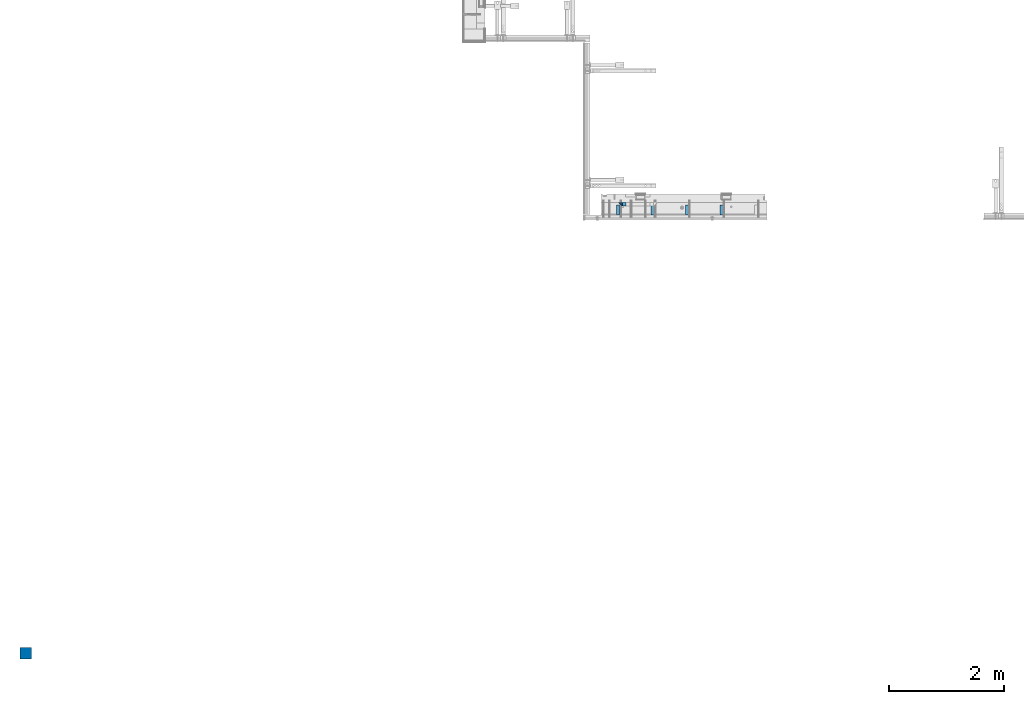
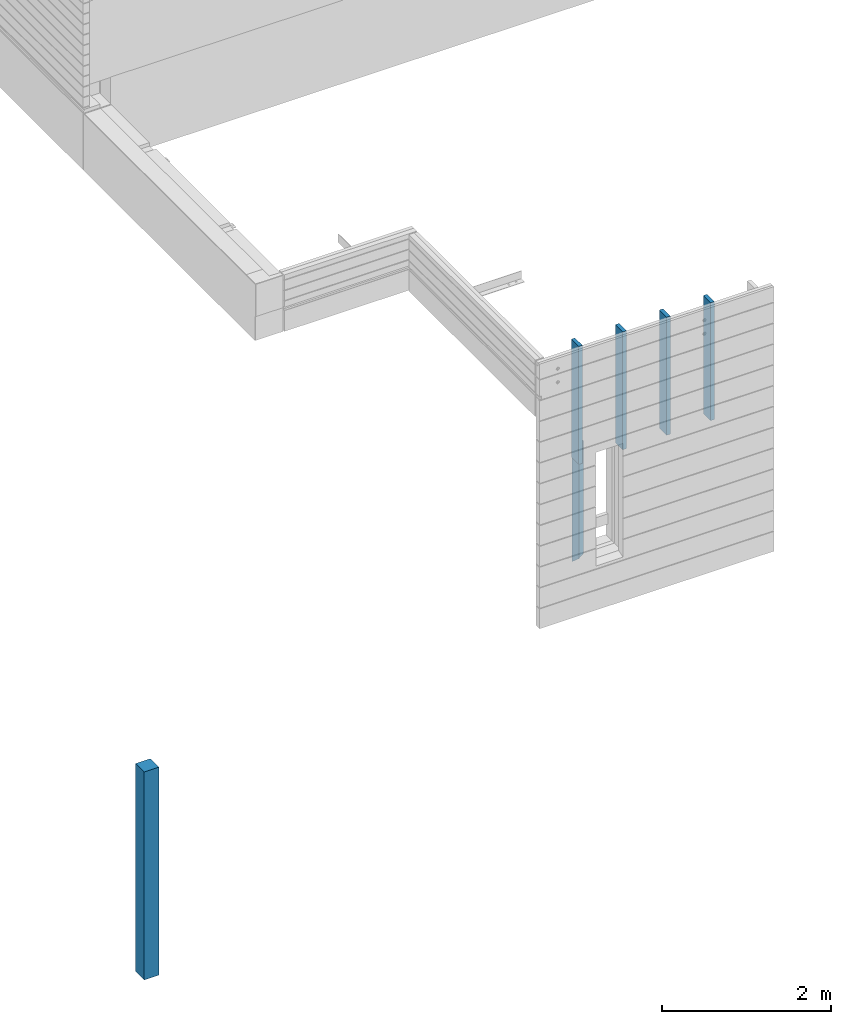
# One storey, part 1 of 153: 7 columns, 2 elements without a shape of their own.
"""IFC2X3 building model written with IfcOpenShell, lengths in millimetres."""

from ifc_helpers import new_model, si_unit, frame, origin_with_axes, place, context, subcontext, project, spatial, faceted_brep, material, type_object, element, aggregate, save


model = new_model("IFC2X3")

# Units and contexts
model_context = context("Model", 3, precision=1e-05, world=origin_with_axes())
body_context = subcontext(model_context, "Body", "Model", "MODEL_VIEW")
ifc_project = project(units=[si_unit("LENGTHUNIT", "METRE", prefix="MILLI"), si_unit("AREAUNIT", "SQUARE_METRE"), si_unit("VOLUMEUNIT", "CUBIC_METRE"), si_unit("MASSUNIT", "GRAM", prefix="KILO"), si_unit("TIMEUNIT", "SECOND"), si_unit("PLANEANGLEUNIT", "RADIAN"), si_unit("SOLIDANGLEUNIT", "STERADIAN"), si_unit("THERMODYNAMICTEMPERATUREUNIT", "DEGREE_CELSIUS"), si_unit("LUMINOUSINTENSITYUNIT", "LUMEN")], contexts=[model_context])

# Site, building, storey
site_placement = place(None, origin_with_axes())
site = spatial("IfcSite", under=ifc_project, at=site_placement, CompositionType="ELEMENT")
building_placement = place(site_placement, origin_with_axes())
building = spatial("IfcBuilding", under=site, at=building_placement, CompositionType="ELEMENT")
storey_placement = place(building_placement, origin_with_axes())
storey = spatial("IfcBuildingStorey", under=building, at=storey_placement, Name="8", CompositionType="ELEMENT", Elevation=0.0)

# Assembly, columns
assembly_1_placement = place(storey_placement, origin_with_axes())
assembly_1 = element("IfcElementAssembly", 1, at=assembly_1_placement, inside=storey, AssemblyPlace="NOTDEFINED", PredefinedType="REINFORCEMENT_UNIT")
ifc_material_1 = material(Name="TIMBER/T24")
column_type_1 = type_object("IfcColumnType", Name="PK50X175", PredefinedType="NOTDEFINED")
column_1_placement = place(assembly_1_placement, frame((10315.0, 7717.5, 101870.0), z_axis=(0.0, 1.0, 0.0), x_axis=(0.0, 0.0, 1.0)))
column_1 = element("IfcColumn", 2, at=column_1_placement, type_object=column_type_1, material=ifc_material_1, ObjectType="PK50X175", context=body_context, shape_type="Brep", body=[
    faceted_brep([(0.0, 25.0, 87.5), (0.0, -25.0, 87.5), (1700.0, -25.0, 87.5), (1700.0, 25.0, 87.5), (0.0, -25.0, -87.5), (1700.0, -25.0, -87.5), (0.0, 25.0, -87.5), (1700.0, 25.0, -87.5)], [[[0, 1, 2, 3]], [[1, 4, 5, 2]], [[4, 6, 7, 5]], [[6, 0, 3, 7]], [[5, 7, 3, 2]], [[6, 4, 1, 0]]]),
])
column_2_placement = place(assembly_1_placement, frame((10915.0, 7717.5, 101870.0), z_axis=(0.0, 1.0, 0.0), x_axis=(0.0, 0.0, 1.0)))
column_2 = element("IfcColumn", 3, at=column_2_placement, type_object=column_type_1, material=ifc_material_1, ObjectType="PK50X175", context=body_context, shape_type="Brep", body=[
    faceted_brep([(0.0, 25.0, 87.5), (0.0, -25.0, 87.5), (1700.0, -25.0, 87.5), (1700.0, 25.0, 87.5), (0.0, -25.0, -87.5), (1700.0, -25.0, -87.5), (0.0, 25.0, -87.5), (1700.0, 25.0, -87.5)], [[[0, 1, 2, 3]], [[1, 4, 5, 2]], [[4, 6, 7, 5]], [[6, 0, 3, 7]], [[5, 7, 3, 2]], [[6, 4, 1, 0]]]),
])
column_3_placement = place(assembly_1_placement, frame((11515.0, 7717.5, 101870.0), z_axis=(0.0, 1.0, 0.0), x_axis=(0.0, 0.0, 1.0)))
column_3 = element("IfcColumn", 4, at=column_3_placement, type_object=column_type_1, material=ifc_material_1, ObjectType="PK50X175", context=body_context, shape_type="Brep", body=[
    faceted_brep([(0.0, 25.0, 87.5), (0.0, -25.0, 87.5), (1700.0, -25.0, 87.5), (1700.0, 25.0, 87.5), (0.0, -25.0, -87.5), (1700.0, -25.0, -87.5), (0.0, 25.0, -87.5), (1700.0, 25.0, -87.5)], [[[0, 1, 2, 3]], [[1, 4, 5, 2]], [[4, 6, 7, 5]], [[6, 0, 3, 7]], [[5, 7, 3, 2]], [[6, 4, 1, 0]]]),
])
column_4_placement = place(assembly_1_placement, frame((12115.0, 7717.5, 101870.0), z_axis=(0.0, 1.0, 0.0), x_axis=(0.0, 0.0, 1.0)))
column_4 = element("IfcColumn", 5, at=column_4_placement, type_object=column_type_1, material=ifc_material_1, ObjectType="PK50X175", context=body_context, shape_type="Brep", body=[
    faceted_brep([(0.0, 25.0, 87.5), (0.0, -25.0, 87.5), (1700.0, -25.0, 87.5), (1700.0, 25.0, 87.5), (0.0, -25.0, -87.5), (1700.0, -25.0, -87.5), (0.0, 25.0, -87.5), (1700.0, 25.0, -87.5)], [[[0, 1, 2, 3]], [[1, 4, 5, 2]], [[4, 6, 7, 5]], [[6, 0, 3, 7]], [[5, 7, 3, 2]], [[6, 4, 1, 0]]]),
])
ifc_material_2 = material(Name="CONCRETE/C25/30")
column_type_2 = type_object("IfcColumnType", PredefinedType="NOTDEFINED")
column_5_placement = place(assembly_1_placement, frame((10354.997879677, 7820.0, 100320.0), z_axis=(1.0, 0.0, 0.0), x_axis=(0.0, 0.0, 1.0)))
column_5 = element("IfcColumn", 6, at=column_5_placement, type_object=column_type_2, material=ifc_material_2, Name="SK", context=body_context, shape_type="Brep", body=[
    faceted_brep([(1795.00000000001, -30.0, 30.0), (1855.0, -30.0, -30.0), (1795.00000000001, 30.0, 30.0), (60.0000000000073, -30.0, 30.0), (0.0, -30.0, -30.0), (60.0000000000073, 30.0, 30.0)], [[[0, 1, 2]], [[1, 0, 3, 4]], [[2, 1, 4, 5]], [[0, 2, 5, 3]], [[5, 4, 3]]]),
])
column_type_3 = type_object("IfcColumnType", PredefinedType="NOTDEFINED")
column_6_placement = place(assembly_1_placement, frame((10419.997879677, 7820.0, 100380.0), z_axis=(1.0, 0.0, 0.0), x_axis=(0.0, 0.0, 1.0)))
column_6 = element("IfcColumn", 7, at=column_6_placement, type_object=column_type_3, material=ifc_material_2, Name="SK", context=body_context, shape_type="Brep", body=[
    faceted_brep([(1735.0, -30.0, -35.0), (1735.0, 30.0, -35.0), (1678.70525582272, 30.0, 30.6772015545812), (1680.09521721235, -30.0, 29.0555799329595), (56.2947441772849, 30.0, 30.6772015545812), (54.9047827876348, -30.0, 29.0555799329595), (0.0, -30.0, -35.0), (0.0, 30.0, -35.0)], [[[0, 1, 2, 3]], [[3, 2, 4, 5]], [[0, 3, 5, 6]], [[1, 0, 6, 7]], [[2, 1, 7, 4]], [[6, 5, 4, 7]]]),
])
aggregate(assembly_1, [column_1, column_2, column_3, column_4, column_5, column_6])

# Assembly, column
assembly_2_placement = place(storey_placement, origin_with_axes())
assembly_2 = element("IfcElementAssembly", 8, at=assembly_2_placement, inside=storey, AssemblyPlace="NOTDEFINED", PredefinedType="REINFORCEMENT_UNIT")
ifc_material_3 = material(Name="CONCRETE/Concrete_Undefined")
column_type_4 = type_object("IfcColumnType", PredefinedType="NOTDEFINED")
column_7_placement = place(assembly_2_placement, frame((0.0, 0.0, 102760.0), z_axis=(0.0, 1.0, 0.0), x_axis=(0.0, 0.0, 1.0)))
column_7 = element("IfcColumn", 9, at=column_7_placement, type_object=column_type_4, material=ifc_material_3, context=body_context, shape_type="Brep", body=[
    faceted_brep([(0.0, 100.0, -100.0), (0.0, 100.0, 100.0), (3000.0, 100.0, 100.0), (3000.0, 100.0, -100.0), (0.0, -100.0, 100.0), (3000.0, -100.0, 100.0), (0.0, -100.0, -100.0), (3000.0, -100.0, -100.0)], [[[0, 1, 2, 3]], [[1, 4, 5, 2]], [[4, 6, 7, 5]], [[6, 0, 3, 7]], [[5, 7, 3, 2]], [[6, 4, 1, 0]]]),
])
aggregate(assembly_2, [column_7])

save(model, "model.ifc")
